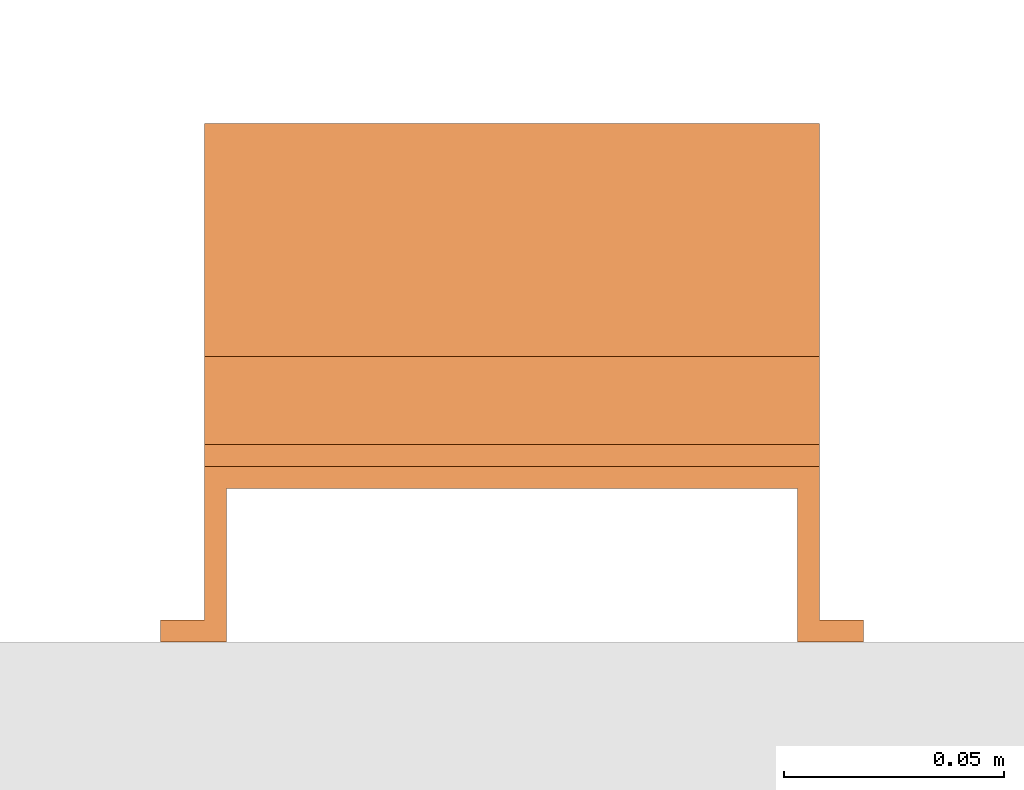
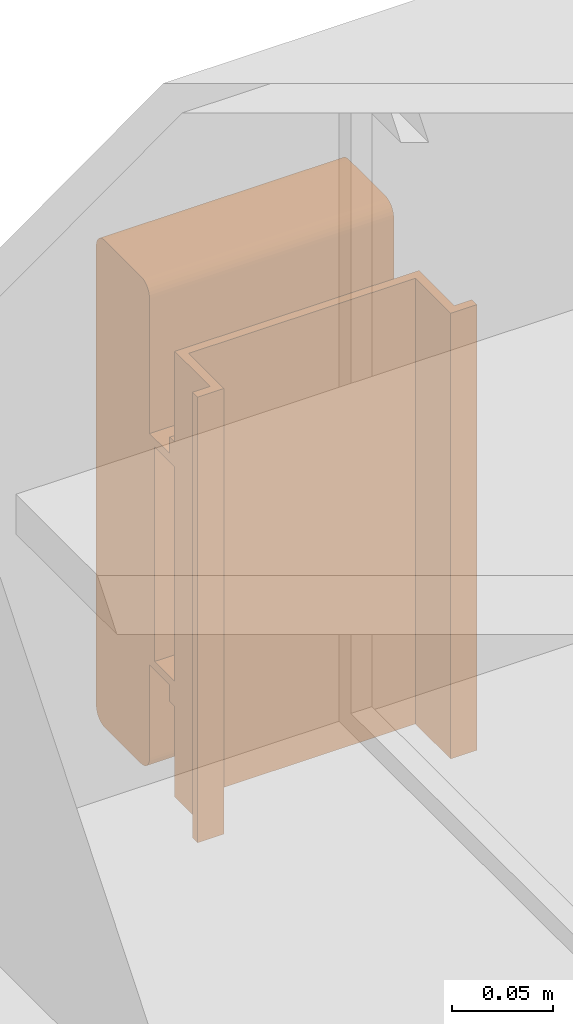
# One storey, part 8 of 8: 1 proxy.
"""IFC2X3 building model written with IfcOpenShell, lengths in millimetres."""

from ifc_helpers import new_model, entity, si_unit, converted_unit, derived_unit, direction, frame, frame_2d, origin, place, context, subcontext, project, spatial, polyline, circle_curve, parameter, trimmed, segment, composite_curve, outline, extrude, source, transform, mapped, material, material_list, type_object, type_shapes, element, save


model = new_model("IFC2X3")

# Units and contexts
model_context = context("Model", 3, precision=0.01, world=origin(), true_north=direction((6.12303176911189e-17, 1.0)))
body_context = subcontext(model_context, "Body", "Model", "MODEL_VIEW")
ifc_project = project(units=[si_unit("LENGTHUNIT", "METRE", prefix="MILLI"), si_unit("AREAUNIT", "SQUARE_METRE"), si_unit("VOLUMEUNIT", "CUBIC_METRE"), converted_unit("PLANEANGLEUNIT", "DEGREE", entity("IfcRatioMeasure", 0.0174532925199433), si_unit("PLANEANGLEUNIT", "RADIAN"), dimensions=[0, 0, 0, 0, 0, 0, 0]), si_unit("MASSUNIT", "GRAM", prefix="KILO"), derived_unit("MASSDENSITYUNIT", [(si_unit("MASSUNIT", "GRAM", prefix="KILO"), 1), (si_unit("LENGTHUNIT", "METRE"), -3)]), derived_unit("MOMENTOFINERTIAUNIT", [(si_unit("LENGTHUNIT", "METRE"), 4)]), si_unit("TIMEUNIT", "SECOND"), si_unit("FREQUENCYUNIT", "HERTZ"), si_unit("THERMODYNAMICTEMPERATUREUNIT", "DEGREE_CELSIUS"), derived_unit("THERMALTRANSMITTANCEUNIT", [(si_unit("MASSUNIT", "GRAM", prefix="KILO"), 1), (si_unit("THERMODYNAMICTEMPERATUREUNIT", "KELVIN"), -1), (si_unit("TIMEUNIT", "SECOND"), -3)]), derived_unit("VOLUMETRICFLOWRATEUNIT", [(si_unit("LENGTHUNIT", "METRE"), 3), (si_unit("TIMEUNIT", "SECOND"), -1)]), derived_unit("MASSFLOWRATEUNIT", [(si_unit("MASSUNIT", "GRAM", prefix="KILO"), 1), (si_unit("TIMEUNIT", "SECOND"), -1)]), derived_unit("ROTATIONALFREQUENCYUNIT", [(si_unit("TIMEUNIT", "SECOND"), -1)]), si_unit("ELECTRICCURRENTUNIT", "AMPERE"), si_unit("ELECTRICVOLTAGEUNIT", "VOLT"), si_unit("POWERUNIT", "WATT"), si_unit("FORCEUNIT", "NEWTON", prefix="KILO"), si_unit("ILLUMINANCEUNIT", "LUX"), si_unit("LUMINOUSFLUXUNIT", "LUMEN"), si_unit("LUMINOUSINTENSITYUNIT", "CANDELA"), derived_unit("USERDEFINED", [(si_unit("MASSUNIT", "GRAM", prefix="KILO"), -1), (si_unit("LENGTHUNIT", "METRE"), -2), (si_unit("TIMEUNIT", "SECOND"), 3), (si_unit("LUMINOUSFLUXUNIT", "LUMEN"), 1)]), derived_unit("LINEARVELOCITYUNIT", [(si_unit("LENGTHUNIT", "METRE"), 1), (si_unit("TIMEUNIT", "SECOND"), -1)]), si_unit("PRESSUREUNIT", "PASCAL"), derived_unit("USERDEFINED", [(si_unit("LENGTHUNIT", "METRE"), -2), (si_unit("MASSUNIT", "GRAM", prefix="KILO"), 1), (si_unit("TIMEUNIT", "SECOND"), -2)]), derived_unit("LINEARFORCEUNIT", [(si_unit("MASSUNIT", "GRAM", prefix="KILO"), 1), (si_unit("LENGTHUNIT", "METRE"), 1), (si_unit("TIMEUNIT", "SECOND"), -2), (si_unit("LENGTHUNIT", "METRE"), -1)]), derived_unit("PLANARFORCEUNIT", [(si_unit("MASSUNIT", "GRAM", prefix="KILO"), 1), (si_unit("LENGTHUNIT", "METRE"), 1), (si_unit("TIMEUNIT", "SECOND"), -2), (si_unit("LENGTHUNIT", "METRE"), -2)])], contexts=[model_context])

# Site, building, storey
site_placement = place(None, frame((0.0, -0.00077364408347762, 0.0)))
site = spatial("IfcSite", under=ifc_project, at=site_placement, CompositionType="ELEMENT")
building_placement = place(site_placement, origin())
building = spatial("IfcBuilding", under=site, at=building_placement, CompositionType="ELEMENT")
storey_placement = place(building_placement, frame((0.0, 0.0, 4200.0)))
storey = spatial("IfcBuildingStorey", under=building, at=storey_placement, CompositionType="ELEMENT", Elevation=4200.0)

# Proxy
ifc_material_1 = material()
ifc_material_2 = material()
ifc_material_list_1 = material_list([ifc_material_1, ifc_material_2])
ifc_material_list_2 = material_list([ifc_material_1, ifc_material_1, ifc_material_2])
building_element_proxy_type = type_object("IfcBuildingElementProxyType", PredefinedType="NOTDEFINED", material=ifc_material_list_2)
shared_shape = source(origin(), body_context, "Body", "SweptSolid", [
    extrude(outline(composite_curve([segment(polyline([(-18.1579434264858, -147.53864987638), (18.0451391047457, -147.53864987638)]), True, "CONTINUOUS"), segment(trimmed(circle_curve(frame_2d((18.0451391047457, -139.094333839161), x_axis=(0.0, -1.0)), 8.44431603721898), [parameter(1.01777749806833e-13)], [parameter(90.0)], True, "PARAMETER"), True, "CONTINUOUS"), segment(polyline([(26.4894551419646, -139.094333839161), (26.4894551419649, 139.30552762976)]), True, "CONTINUOUS"), segment(trimmed(circle_curve(frame_2d((18.3336326481045, 139.30552762976), x_axis=(0.0, -1.0)), 8.15582249386043), [parameter(90.0)], [parameter(180.0)], True, "PARAMETER"), True, "CONTINUOUS"), segment(polyline([(18.3336326481046, 147.46135012362), (-18.1786488941653, 147.461350123621)]), True, "CONTINUOUS"), segment(trimmed(circle_curve(frame_2d((-18.1786488941652, 139.129454159721), x_axis=(0.0, -1.0)), 8.33189596389998), [parameter(180.0)], [parameter(270.0)], True, "PARAMETER"), True, "CONTINUOUS"), segment(polyline([(-26.5105448580647, 139.129454159721), (-26.5105448580641, -139.186048444801)]), True, "CONTINUOUS"), segment(trimmed(circle_curve(frame_2d((-18.1579434264858, -139.186048444801), x_axis=(0.0, -1.0)), 8.35260143157827), [parameter(270.0)], [parameter(4.57999874130747e-13)], True, "PARAMETER"), True, "CONTINUOUS")], self_intersect=False)), frame((-70.0, 12.5386498763715, 91.489455141968), z_axis=(1.0, 0.0, 0.0), x_axis=(0.0, 0.0, -1.0)), (0.0, 0.0, 1.0), 139.999999999992),
    extrude(outline(polyline([(-9.1666666666746, -80.0), (-4.16666666666706, -80.0), (-4.16666666667189, -70.0), (15.8333333333402, -70.0), (15.8333333333402, 70.0), (-4.16666666666706, 70.0), (-4.16666666666706, 80.0), (-9.16666666667441, 80.0), (-9.16666666667492, 65.0), (10.8333333333455, 65.0), (10.8333333333455, -65.0), (-9.16666666667441, -65.0), (-9.1666666666746, -80.0)])), frame((-70.0, 0.0, 49.1666666666727), z_axis=(1.0, 0.0, 0.0), x_axis=(0.0, 0.0, 1.0)), (0.0, 0.0, 1.0), 139.999999999992),
    extrude(outline(polyline([(-14.1666666666698, -80.0), (-9.16666666666213, -80.0), (-9.16666666666697, -70.0), (25.833333333333, -70.0), (25.833333333333, 70.0), (-9.16666666666213, 70.0), (-9.16666666666211, 80.0), (-14.1666666666695, 80.0), (-14.16666666667, 65.0), (20.833333333333, 65.0), (20.833333333333, -65.0), (-14.1666666666695, -65.0), (-14.1666666666698, -80.0)])), frame((0.0, -135.0, 14.1666666666679), z_axis=(0.0, 1.0, 0.0), x_axis=(0.0, 0.0, 1.0)), (0.0, 0.0, 1.0), 270.0),
])
type_shapes(building_element_proxy_type, [shared_shape])
proxy_placement = place(storey_placement, frame((63869.9717068776, 10197.4036709343, 2580.0), z_axis=(-7.41605990184926e-05, 0.999999997250103, 0.0), x_axis=(-0.999999997250103, -7.41605990184926e-05, 0.0)))
element("IfcBuildingElementProxy", 1, at=proxy_placement, inside=storey, type_object=building_element_proxy_type, material=ifc_material_list_1, context=body_context, shape_type="MappedRepresentation", body=[
    mapped(shared_shape, transform((0.0, 0.0, 0.0), scale=1.0)),
])

save(model, "model.ifc")
